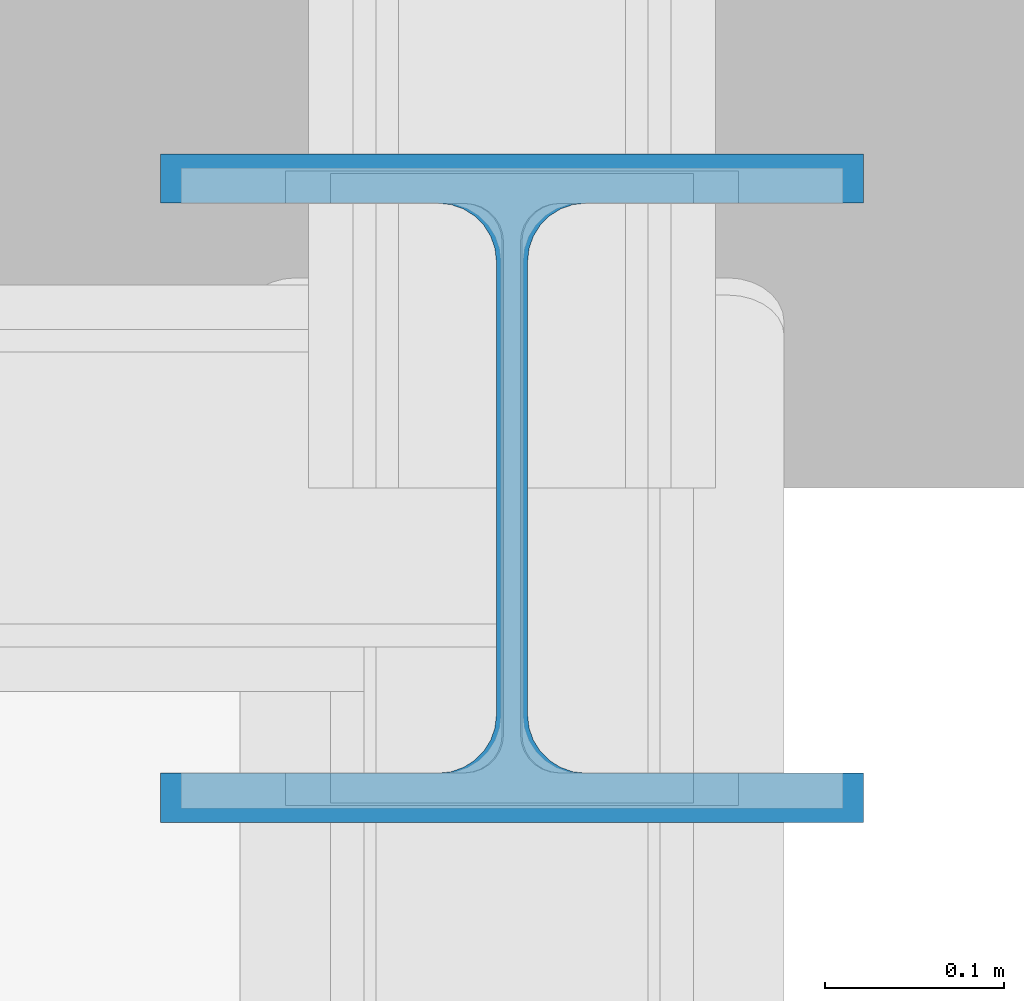
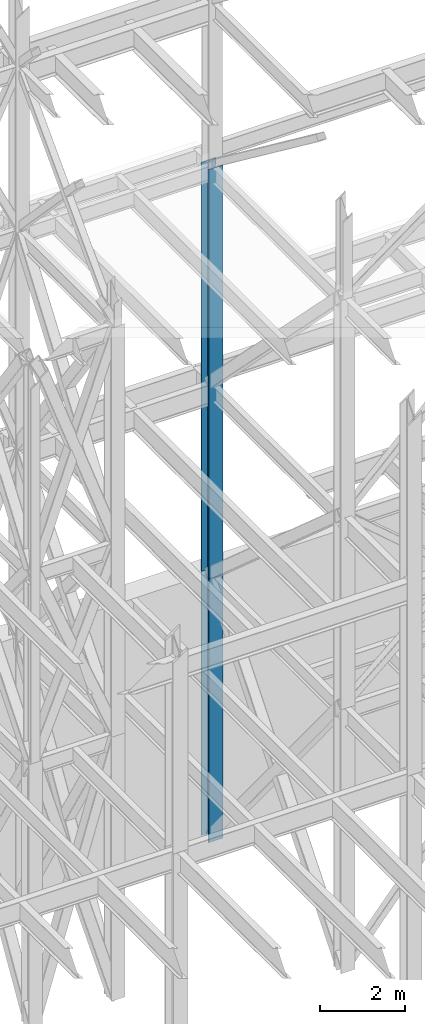
# One storey, part 117 of 150: 2 columns.
"""IFC2X3 building model written with IfcOpenShell, lengths in millimetres."""

from ifc_helpers import new_model, si_unit, frame, origin_with_axes, origin_2d_with_axis, place, context, subcontext, project, spatial, i_section, extrude, material, type_object, element, save


model = new_model("IFC2X3")

# Units and contexts
model_context = context("Model", 3, precision=1e-05, world=origin_with_axes())
body_context = subcontext(model_context, "Body", "Model", "MODEL_VIEW")
ifc_project = project(units=[si_unit("LENGTHUNIT", "METRE", prefix="MILLI"), si_unit("AREAUNIT", "SQUARE_METRE"), si_unit("VOLUMEUNIT", "CUBIC_METRE"), si_unit("MASSUNIT", "GRAM", prefix="KILO"), si_unit("TIMEUNIT", "SECOND"), si_unit("PLANEANGLEUNIT", "RADIAN"), si_unit("SOLIDANGLEUNIT", "STERADIAN"), si_unit("THERMODYNAMICTEMPERATUREUNIT", "DEGREE_CELSIUS"), si_unit("LUMINOUSINTENSITYUNIT", "LUMEN")], contexts=[model_context])

# Site, building, storey
site_placement = place(None, origin_with_axes())
site = spatial("IfcSite", under=ifc_project, at=site_placement, CompositionType="ELEMENT")
building_placement = place(site_placement, origin_with_axes())
building = spatial("IfcBuilding", under=site, at=building_placement, Name="Undefined", CompositionType="ELEMENT")
storey_placement = place(building_placement, origin_with_axes())
storey = spatial("IfcBuildingStorey", under=building, at=storey_placement, Name="Undefined", CompositionType="ELEMENT", Elevation=0.0)

# Columns
ifc_material = material(Name="STEEL/A992")
column_type = type_object("IfcColumnType", Name="W14X145", PredefinedType="NOTDEFINED")
column_1_placement = place(storey_placement, frame((82194.4, 31877.0, 23774.4), z_axis=(0.0, 0.0, 1.0), x_axis=(1.0, 0.0, 0.0)))
element("IfcColumn", 1, at=column_1_placement, inside=storey, type_object=column_type, material=ifc_material, Name="COLUMN", ObjectType="W14X145", context=body_context, shape_type="SweptSolid", body=[
    extrude(i_section(OverallWidth=393.7, OverallDepth=374.65, WebThickness=17.4625, FlangeThickness=27.686, FilletRadius=32.6389, at=origin_2d_with_axis()), frame((0.0, 0.0, 11811.0), z_axis=(0.0, 0.0, -1.0), x_axis=(-1.0, 0.0, 0.0)), (0.0, 0.0, 1.0), 11811.0),
])
column_2_placement = place(storey_placement, frame((82194.4, 31877.0, 16154.4), z_axis=(0.0, 0.0, 1.0), x_axis=(1.0, 0.0, 0.0)))
element("IfcColumn", 2, at=column_2_placement, inside=storey, type_object=column_type, material=ifc_material, Name="COLUMN", ObjectType="W14X145", context=body_context, shape_type="SweptSolid", body=[
    extrude(i_section(OverallWidth=393.7, OverallDepth=374.65, WebThickness=17.4625, FlangeThickness=27.686, FilletRadius=32.6389, at=origin_2d_with_axis()), frame((0.0, 0.0, 7620.0), z_axis=(0.0, 0.0, -1.0), x_axis=(-1.0, 0.0, 0.0)), (0.0, 0.0, 1.0), 7620.0),
])

save(model, "model.ifc")
